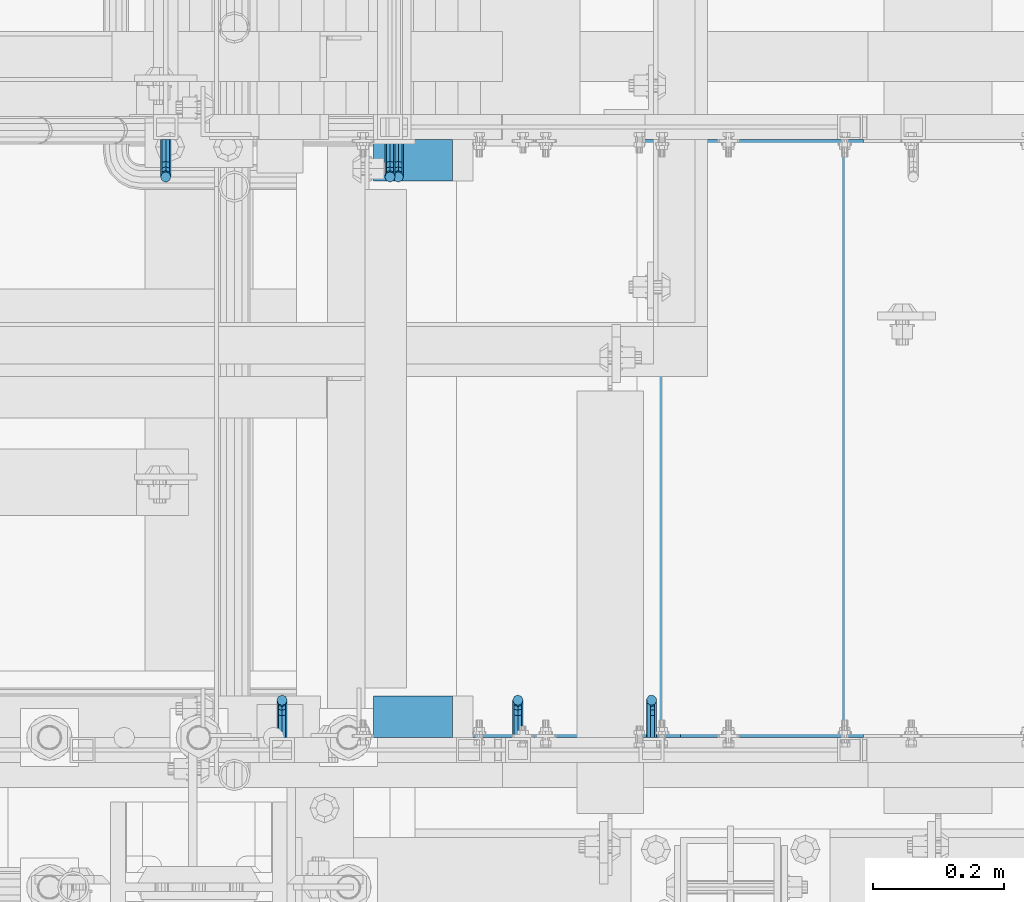
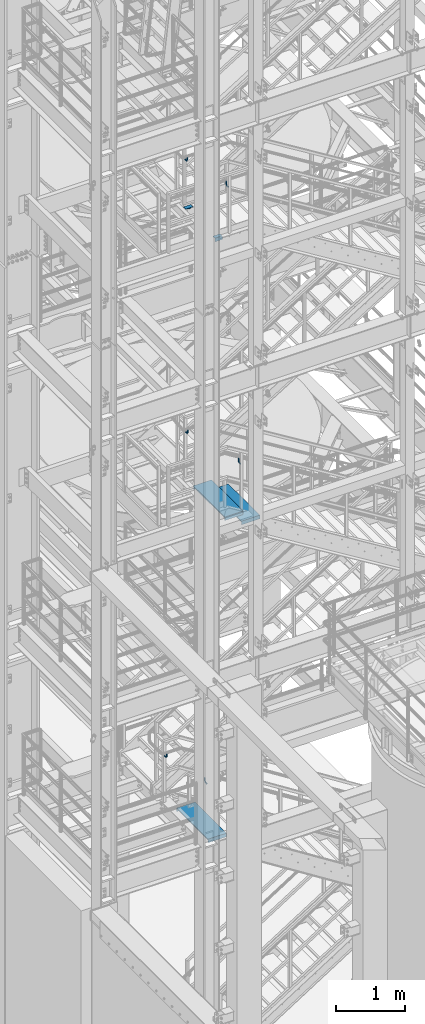
# One storey, part 1135 of 1876: 11 beams, 9 elements without a shape of their own.
"""IFC2X3 building model written with IfcOpenShell, lengths in millimetres."""

import ifcopenshell
import ifcopenshell.guid

model = None  # the IFC model being written
_history = None  # IfcOwnerHistory: only IFC2X3 demands one
_inside = {}  # id of a spatial element -> (the spatial element, [elements in it])
_under = {}  # id of a project, library or spatial element -> (it, [spatial elements below it])
_declared = {}  # id of a project -> (the project, [libraries it declares])
_typed = {}  # id of a type object -> (the type object, [elements of that type])
_made_of = {}  # id of a material, layer set ... -> (it, [elements and type objects made of it])


def new_model(schema):
    """Start an empty IFC model of exactly this schema.

    Asked for "IFC4X3", IfcOpenShell would pick the latest addendum, in which some entities
    have other attributes; the version numbers below select the first issue.
    IFC2X3 requires an IfcOwnerHistory on every rooted entity: one is made here for all.
    """
    global model, _history
    if schema == "IFC4X3":
        model = ifcopenshell.file(schema_version=(4, 3, 0, 0))
    else:
        model = ifcopenshell.file(schema=schema)
    _inside.clear()
    _under.clear()
    _declared.clear()
    _typed.clear()
    _made_of.clear()
    _history = None
    if model.schema == "IFC2X3":
        org = make("IfcOrganization", Name="unknown")
        user = make(
            "IfcPersonAndOrganization",
            ThePerson=make("IfcPerson", FamilyName="unknown"),
            TheOrganization=org,
        )
        app = make(
            "IfcApplication",
            ApplicationDeveloper=org,
            Version="unknown",
            ApplicationFullName="unknown",
            ApplicationIdentifier="unknown",
        )
        _history = make(
            "IfcOwnerHistory",
            OwningUser=user,
            OwningApplication=app,
            ChangeAction="ADDED",
            CreationDate=0,
        )
    return model


def make(cls, **values):
    """One entity of the class cls with the attributes given. An attribute that is None is left unset."""
    return model.create_entity(
        cls, **{name: value for name, value in values.items() if value is not None}
    )


def rooted(cls, **values):
    """An entity with a GlobalId (a new one), such as an element, a storey or a relation."""
    return make(cls, GlobalId=ifcopenshell.guid.new(), OwnerHistory=_history, **values)


def si_unit(unit_type, name, prefix=None):
    """IfcSIUnit, for example si_unit("LENGTHUNIT", "METRE", prefix="MILLI")."""
    return make("IfcSIUnit", UnitType=unit_type, Prefix=prefix, Name=name)


def assignment(units):
    """IfcUnitAssignment: the units of a project."""
    return None if units is None else make("IfcUnitAssignment", Units=units)


def point(xyz):
    """IfcCartesianPoint."""
    return None if xyz is None else make("IfcCartesianPoint", Coordinates=xyz)


def direction(xyz):
    """IfcDirection."""
    return None if xyz is None else make("IfcDirection", DirectionRatios=xyz)


def frame(location, z_axis=None, x_axis=None):
    """IfcAxis2Placement3D, a coordinate frame: its origin and axes. An axis left out is left unset."""
    return make(
        "IfcAxis2Placement3D",
        Location=point(location),
        Axis=direction(z_axis),
        RefDirection=direction(x_axis),
    )


def origin_with_axes():
    """The frame at (0, 0, 0) with the z axis (0, 0, 1) and the x axis (1, 0, 0) written out."""
    return frame((0.0, 0.0, 0.0), z_axis=(0.0, 0.0, 1.0), x_axis=(1.0, 0.0, 0.0))


def place(relative_to, where):
    """IfcLocalPlacement: puts the frame where relative to a parent placement (None: the world)."""
    return make(
        "IfcLocalPlacement", PlacementRelTo=relative_to, RelativePlacement=where
    )


def context(
    kind, dimensions, precision=None, world=None, true_north=None, identifier=None
):
    """IfcGeometricRepresentationContext, for example the 3D "Model" context."""
    return make(
        "IfcGeometricRepresentationContext",
        ContextIdentifier=identifier,
        ContextType=kind,
        CoordinateSpaceDimension=dimensions,
        Precision=precision,
        WorldCoordinateSystem=world,
        TrueNorth=true_north,
    )


def subcontext(parent, identifier, kind, view, scale=None):
    """IfcGeometricRepresentationSubContext, for example "Body" below "Model"."""
    return make(
        "IfcGeometricRepresentationSubContext",
        ContextIdentifier=identifier,
        ContextType=kind,
        ParentContext=parent,
        TargetScale=scale,
        TargetView=view,
    )


def project(units=None, contexts=None):
    """IfcProject with its units and contexts."""
    return rooted(
        "IfcProject",
        Name="project",
        RepresentationContexts=contexts,
        UnitsInContext=assignment(units),
    )


def spatial(cls, under=None, at=None, **own):
    """A site, building, storey or space (cls), placed at a placement, below another one or the project."""
    s = rooted(cls, ObjectPlacement=at, **own)
    if under is not None:
        _under.setdefault(under.id(), (under, []))[1].append(s)
    return s


def faces_of(points, faces, orient=None, outer=None):
    """IfcFace entities. A face is a list of loops; a loop is a list of indices into points, from 0.

    orient and outer hold one flag for each loop. By default every Orientation is true, the
    first loop of a face is its IfcFaceOuterBound and the others are IfcFaceBound.
    """
    made = []
    for i, loops in enumerate(faces):
        bounds = []
        for j, loop in enumerate(loops):
            is_outer = j == 0 if outer is None else outer[i][j]
            bounds.append(
                make(
                    "IfcFaceOuterBound" if is_outer else "IfcFaceBound",
                    Bound=make("IfcPolyLoop", Polygon=[points[k] for k in loop]),
                    Orientation=True if orient is None else orient[i][j],
                )
            )
        made.append(make("IfcFace", Bounds=bounds))
    return made


def faceted_brep(points, faces, orient=None, outer=None, voids=None):
    """IfcFacetedBrep: a solid bounded by flat faces; with voids (closed shells), ...WithVoids."""
    shared = [point(p) for p in points]
    hull = make("IfcClosedShell", CfsFaces=faces_of(shared, faces, orient, outer))
    if voids is None:
        return make("IfcFacetedBrep", Outer=hull)
    return make(
        "IfcFacetedBrepWithVoids",
        Outer=hull,
        Voids=[
            make(cls, CfsFaces=faces_of(shared, fs, o, b)) for cls, fs, o, b in voids
        ],
    )


def shape(context_of_items, identifier, shape_type, items):
    """IfcShapeRepresentation: the items that make up one representation, for example the "Body"."""
    return make(
        "IfcShapeRepresentation",
        ContextOfItems=context_of_items,
        RepresentationIdentifier=identifier,
        RepresentationType=shape_type,
        Items=items,
    )


def material(Name=None, Category=None):
    """IfcMaterial."""
    return make("IfcMaterial", Name=Name, Category=Category)


def made_of(thing, what):
    """Note that an element or type object is made of a material, layer set ...; save() writes the relation."""
    if what is not None:
        _made_of.setdefault(what.id(), (what, []))[1].append(thing)
    return thing


def type_object(cls, material=None, **own):
    """A type object (cls), such as IfcWallType, which elements share."""
    return made_of(rooted(cls, **own), material)


def element(
    cls,
    number,
    at=None,
    inside=None,
    cuts=None,
    type_object=None,
    material=None,
    context=None,
    identifier="Body",
    shape_type=None,
    held_by="IfcProductDefinitionShape",
    body=None,
    shapes=None,
    **own,
):
    """One element of the class cls, such as IfcWall. Its Tag is "e" and its number.

    at: its placement. inside: the storey or other place that contains it. cuts: it is an
    opening in that element (IfcRelVoidsElement). A single representation is given by context,
    identifier, shape_type and body (its items); several are given by shapes. held_by: the class
    of the entity that holds the representations. save() writes the other relations.
    """
    e = rooted(cls, Tag="e%d" % number, ObjectPlacement=at, **own)
    if body is not None:
        shapes = [shape(context, identifier, shape_type, body)]
    if shapes is not None:
        e.Representation = make(held_by, Representations=shapes)
    if inside is not None:
        _inside.setdefault(inside.id(), (inside, []))[1].append(e)
    if cuts is not None:
        rooted(
            "IfcRelVoidsElement", RelatingBuildingElement=cuts, RelatedOpeningElement=e
        )
    if type_object is not None:
        _typed.setdefault(type_object.id(), (type_object, []))[1].append(e)
    return made_of(e, material)


def aggregate(whole, parts):
    """IfcRelAggregates: a whole, such as a stair, and the parts it consists of."""
    return rooted("IfcRelAggregates", RelatingObject=whole, RelatedObjects=parts)


def save(model, path):
    """Write the relations noted so far, then the file.

    IfcRelAggregates (storeys below a building ...), IfcRelContainedInSpatialStructure (elements
    in a storey), IfcRelDefinesByType, IfcRelAssociatesMaterial and IfcRelDeclares: one each for
    every whole, place, type object, material and project.
    """
    for whole, parts in _under.values():
        aggregate(whole, parts)
    for where, things in _inside.values():
        rooted(
            "IfcRelContainedInSpatialStructure",
            RelatedElements=things,
            RelatingStructure=where,
        )
    for kind, things in _typed.values():
        rooted("IfcRelDefinesByType", RelatedObjects=things, RelatingType=kind)
    for what, things in _made_of.values():
        rooted("IfcRelAssociatesMaterial", RelatedObjects=things, RelatingMaterial=what)
    for by, libraries in _declared.values():
        rooted("IfcRelDeclares", RelatingContext=by, RelatedDefinitions=libraries)
    model.write(path)


model = new_model("IFC2X3")

# Units and contexts
model_context = context("Model", 3, precision=1e-05, world=origin_with_axes())
body_context = subcontext(model_context, "Body", "Model", "MODEL_VIEW")
ifc_project = project(units=[si_unit("LENGTHUNIT", "METRE", prefix="MILLI"), si_unit("AREAUNIT", "SQUARE_METRE"), si_unit("VOLUMEUNIT", "CUBIC_METRE"), si_unit("MASSUNIT", "GRAM", prefix="KILO"), si_unit("TIMEUNIT", "SECOND"), si_unit("PLANEANGLEUNIT", "RADIAN"), si_unit("SOLIDANGLEUNIT", "STERADIAN"), si_unit("THERMODYNAMICTEMPERATUREUNIT", "DEGREE_CELSIUS"), si_unit("LUMINOUSINTENSITYUNIT", "LUMEN")], contexts=[model_context])

# Site, building, storey
site_placement = place(None, origin_with_axes())
site = spatial("IfcSite", under=ifc_project, at=site_placement, CompositionType="ELEMENT")
building_placement = place(site_placement, origin_with_axes())
building = spatial("IfcBuilding", under=site, at=building_placement, Name="Undefined", CompositionType="ELEMENT")
storey_placement = place(building_placement, origin_with_axes())
storey = spatial("IfcBuildingStorey", under=building, at=storey_placement, Name="Undefined", CompositionType="ELEMENT", Elevation=0.0)

# Assembly, beams
assembly_1_placement = place(storey_placement, origin_with_axes())
assembly_1 = element("IfcElementAssembly", 1, at=assembly_1_placement, inside=storey, Name="STRINGER", AssemblyPlace="NOTDEFINED", PredefinedType="RIGID_FRAME")
ifc_material = material(Name="STEEL/A36")
beam_type_1 = type_object("IfcBeamType", Name="L2-1/2X2-1/2X1/4", PredefinedType="NOTDEFINED")
beam_1_placement = place(assembly_1_placement, frame((1993.89992675781, -6000.74999885443, 15531.2768518519), z_axis=(0.0, -1.0, 0.0), x_axis=(1.0, 0.0, 0.0)))
beam_1 = element("IfcBeam", 2, at=beam_1_placement, type_object=beam_type_1, material=ifc_material, Name="ANGLE", ObjectType="L2-1/2X2-1/2X1/4", context=body_context, shape_type="Brep", body=[
    faceted_brep([(0.0, 18.9900739633831, -25.3999999999996), (0.0, 18.9900743443777, -31.75), (76.2000738000577, 18.9900747300744, -31.75), (76.2000738000577, 18.990074349078, -25.3999999999996), (76.200071516754, -31.7499998086369, -25.3999999999996), (76.200071516754, -31.75, -31.75), (0.0, 25.3999999999996, 31.75), (0.0, 25.3999999999996, -25.3999999999996), (120.650073242187, 25.3999999999996, -25.3999999999996), (120.650073242187, 25.3999999999996, 31.75), (0.0, 31.75, 31.75), (120.650073242187, 31.75, 31.75), (0.0, 31.75, -31.75), (120.650073242187, 31.75, -31.75), (120.650073242187, -31.75, -25.3999999999996), (120.650073242187, -31.75, -31.75)], [[[0, 1, 2, 3]], [[4, 3, 2, 5]], [[6, 7, 8, 9]], [[10, 6, 9, 11]], [[12, 10, 11, 13]], [[9, 8, 14, 15, 13, 11]], [[15, 14, 4, 5]], [[1, 12, 13, 15, 5, 2]], [[7, 6, 10, 12, 1, 0]], [[14, 8, 7, 0, 3, 4]]]),
])
beam_2_placement = place(assembly_1_placement, frame((2114.55, -6851.65000114557, 15531.2768518519), z_axis=(0.0, 1.0, 0.0), x_axis=(-1.0, 0.0, 0.0)))
beam_2 = element("IfcBeam", 3, at=beam_2_placement, type_object=beam_type_1, material=ifc_material, Name="ANGLE", ObjectType="L2-1/2X2-1/2X1/4", context=body_context, shape_type="Brep", body=[
    faceted_brep([(0.0, 31.75, -31.75), (0.0, 31.75, 31.75), (120.650073242187, 31.75, 31.75), (120.650073242187, 31.75, -31.75), (0.0, 25.3999999999996, 31.75), (120.650073242187, 25.3999999999996, 31.75), (0.0, 25.3999999999996, -25.3999999999996), (120.650073242187, 25.3999999999996, -25.3999999999996), (0.0, -31.75, -25.3999999999996), (120.650073242187, -31.75, -25.3999999999996), (0.0, -31.75, -31.75), (120.650073242187, -31.75, -31.75)], [[[0, 1, 2, 3]], [[1, 4, 5, 2]], [[4, 6, 7, 5]], [[6, 8, 9, 7]], [[8, 10, 11, 9]], [[10, 0, 3, 11]], [[5, 7, 9, 11, 3, 2]], [[10, 8, 6, 4, 1, 0]]]),
])
aggregate(assembly_1, [beam_1, beam_2])

# Assembly, beam
assembly_2_placement = place(storey_placement, origin_with_axes())
assembly_2 = element("IfcElementAssembly", 4, at=assembly_2_placement, inside=storey, Name="RAIL", AssemblyPlace="NOTDEFINED", PredefinedType="RIGID_FRAME")
beam_type_2 = type_object("IfcBeamType", PredefinedType="NOTDEFINED")
beam_3_placement = place(assembly_2_placement, frame((1676.39999604434, -5969.00000106773, 5956.3), z_axis=(-1.0, 0.0, 0.0), x_axis=(0.0, -1.0, 0.0)))
beam_3 = element("IfcBeam", 5, at=beam_3_placement, type_object=beam_type_2, material=ifc_material, Name="BRACKET", context=body_context, shape_type="Brep", body=[
    faceted_brep([(0.0, -7.9375, 0.0), (0.0, -5.61266007566822, -5.61266007566883), (23.8125, -5.61266007566883, -5.61266007566792), (23.8125, -7.9375, 0.0), (0.0, 0.0, -7.9375), (23.8125, 0.0, -7.9375), (0.0, 5.61266007566822, -5.61266007566883), (23.8125, 5.61266007566883, -5.61266007566792), (0.0, 7.9375, 0.0), (23.8125, 7.9375, 0.0), (0.0, 5.61266007566822, 5.61266007566883), (23.8125, 5.61266007566883, 5.61266007566792), (0.0, 0.0, 7.9375), (23.8125, 0.0, 7.9375), (0.0, -5.61266007566822, 5.61266007566883), (23.8125, -5.61266007566883, 5.61266007566792), (39.6077592547981, -4.79562758825341, 0.0), (38.7180815328556, -2.64775556579843, 5.61266007566792), (36.5702095103998, 2.53766620105671, 7.9375), (34.4223374879448, 7.72308796790821, 5.61266007566792), (33.5326597660023, 9.87095999036319, 0.0), (34.4223374879448, 7.72308796790821, -5.61266007566792), (36.5702095103998, 2.53766620105671, -7.9375), (38.7180815328556, -2.64775556579843, -5.61266007566792), (51.3544233967659, 5.79557812911298, -5.61266007566792), (52.9983334724348, 4.15166805344415, 0.0), (47.3856733967659, 9.76432812911298, -7.9375), (43.4169233967659, 13.733078129113, -5.61266007566792), (41.773013321098, 15.3769882047818, 0.0), (43.4169233967659, 13.733078129113, 5.61266007566792), (47.3856733967659, 9.76432812911298, 7.9375), (51.3544233967659, 5.79557812911298, 5.61266007566792), (59.7977570916764, 18.4319199930251, -5.61266007566792), (61.9456291141314, 17.5422422710835, 0.0), (54.6123353248231, 20.5797920154801, -7.9375), (49.4269135579698, 22.727664037935, -5.61266007566792), (47.2790415355148, 23.6173417598766, 0.0), (49.4269135579698, 22.727664037935, 5.61266007566792), (54.6123353248231, 20.5797920154801, 7.9375), (59.7977570916764, 18.4319199930251, 5.61266007566792), (62.7626616015468, 33.3375015258789, -5.61266007566792), (65.0875015258789, 33.3375015258789, 0.0), (57.1500015258789, 33.3375015258789, -7.9375), (51.5373414502101, 33.3375015258789, -5.61266007566792), (49.2125015258789, 33.3375015258789, 0.0), (51.5373414502101, 33.3375015258789, 5.61266007566792), (57.1500015258789, 33.3375015258789, 7.9375), (62.7626616015468, 33.3375015258789, 5.61266007566792), (62.7626616015468, 69.8499984741211, -5.61266007566792), (65.0875015258789, 69.8499984741211, 0.0), (57.1500015258789, 69.8499984741211, -7.9375), (51.537341450211, 69.8499984741211, -5.61266007566792), (49.2125015258789, 69.8499984741211, 0.0), (51.537341450211, 69.8499984741211, 5.61266007566792), (57.1500015258789, 69.8499984741211, 7.9375), (62.7626616015468, 69.8499984741211, 5.61266007566792)], [[[0, 1, 2, 3]], [[1, 4, 5, 2]], [[4, 6, 7, 5]], [[6, 8, 9, 7]], [[8, 10, 11, 9]], [[10, 12, 13, 11]], [[12, 14, 15, 13]], [[14, 0, 3, 15]], [[14, 12, 10, 8, 6, 4, 1, 0]], [[15, 3, 16, 17]], [[13, 15, 17, 18]], [[11, 13, 18, 19]], [[9, 11, 19, 20]], [[7, 9, 20, 21]], [[5, 7, 21, 22]], [[2, 5, 22, 23]], [[3, 2, 23, 16]], [[23, 24, 25, 16]], [[22, 26, 24, 23]], [[21, 27, 26, 22]], [[20, 28, 27, 21]], [[19, 29, 28, 20]], [[18, 30, 29, 19]], [[17, 31, 30, 18]], [[16, 25, 31, 17]], [[24, 32, 33, 25]], [[26, 34, 32, 24]], [[27, 35, 34, 26]], [[28, 36, 35, 27]], [[29, 37, 36, 28]], [[30, 38, 37, 29]], [[31, 39, 38, 30]], [[25, 33, 39, 31]], [[32, 40, 41, 33]], [[34, 42, 40, 32]], [[35, 43, 42, 34]], [[36, 44, 43, 35]], [[37, 45, 44, 36]], [[38, 46, 45, 37]], [[39, 47, 46, 38]], [[33, 41, 47, 39]], [[41, 40, 48, 49]], [[40, 42, 50, 48]], [[42, 43, 51, 50]], [[43, 44, 52, 51]], [[44, 45, 53, 52]], [[45, 46, 54, 53]], [[46, 47, 55, 54]], [[47, 41, 49, 55]], [[50, 51, 52, 53, 54, 55, 49, 48]]]),
])
aggregate(assembly_2, [beam_3])

assembly_3_placement = place(storey_placement, origin_with_axes())
assembly_3 = element("IfcElementAssembly", 6, at=assembly_3_placement, inside=storey, Name="RAIL", AssemblyPlace="NOTDEFINED", PredefinedType="RIGID_FRAME")
beam_4_placement = place(assembly_3_placement, frame((2419.3500007981, -6883.39999885446, 11421.9952072148), z_axis=(-0.851746923791363, 0.0, 0.523953411871657), x_axis=(0.0, 1.0, 0.0)))
beam_4 = element("IfcBeam", 7, at=beam_4_placement, type_object=beam_type_2, material=ifc_material, Name="BRACKET", context=body_context, shape_type="Brep", body=[
    faceted_brep([(0.0, -5.61266007566822, 5.61266007566883), (0.0, 0.0, 7.9375), (0.0, 5.61266007566822, 5.61266007566883), (0.0, 7.9375, 0.0), (0.0, 5.61266007566822, -5.61266007566883), (0.0, 0.0, -7.9375), (0.0, -5.61266007566822, -5.61266007566883), (0.0, -7.9375, 0.0), (23.8125, 7.9375, 0.0), (23.8125, 5.61266007566883, -5.61266007566792), (23.8125, 0.0, -7.9375), (23.8125, -5.61266007566883, -5.61266007566792), (23.8125, -7.9375, 0.0), (23.8125, -5.61266007566883, 5.61266007566792), (23.8125, 0.0, 7.9375), (23.8125, 5.61266007566883, 5.61266007566792), (37.2742680237907, 3.33192699189385, 7.01565649095653), (39.15743316105, 5.33771543479088, 1.59926141794483), (39.5250377726497, 2.95059483544173, -3.97508660603592), (38.1617440627024, -2.43109193407145, -6.44201010992776), (35.8661509970007, -7.65482575261558, -4.3564187624853), (33.9829858597423, -9.66061419551443, 1.05997631052549), (33.6153812481443, -7.27349359616528, 6.63432433450714), (34.9786749580899, -1.89180682665028, 9.10124783839899), (44.4449010004428, -7.27921686651098, 12.4153212945938), (48.6866038971966, -3.16305132232992, 11.0110522507902), (41.9258626896017, -12.0031473096369, 9.54377798901703), (42.605107443027, -14.5676282658369, 4.07853345752562), (46.0847428963316, -13.4704215714119, -0.778946175020906), (50.3264457930854, -9.35425602723262, -2.18321521882456), (52.8454841039247, -4.63032558410305, 0.688328086752222), (52.1662393505012, -2.0658446279067, 6.15357261824545), (56.3120829365644, -12.8834732957839, 16.9905845690854), (60.8584457511233, -13.1460552819772, 12.9695810055836), (50.7700310236578, -15.3420457780048, 17.3751827270333), (47.4787488596085, -19.0815743126295, 13.8980830945646), (48.3662248985192, -21.9114938009589, 8.59612347865811), (52.9125877130791, -22.1740757871521, 4.57511991515719), (58.4546396259857, -19.715503304933, 4.19052175720924), (61.7459217900359, -15.9759747703083, 7.66762138967886), (63.9107427334729, -26.2160548977063, 21.0096110902649), (64.8713398759373, -29.3590804831365, 15.9002591648249), (58.9897950832947, -24.3494927988595, 24.0439238549806), (52.991121319149, -24.8528009490874, 23.2257381938842), (49.4286631758196, -27.4311482600406, 19.0343361707063), (50.389260318284, -30.5741738454726, 13.9249842452672), (55.3102079684622, -32.4407359443194, 10.8906714805506), (61.3088817326088, -31.9374277940915, 11.7088571416479), (64.8713398759373, -56.6704316393188, 32.700878247072), (61.3088817326088, -56.6704314004855, 26.9234018184987), (55.3102079684622, -56.670431353863, 25.7956053568267), (50.389260318284, -56.6704315267634, 29.9781367337081), (49.4286631758196, -56.6704318179036, 37.0209257936175), (52.991121319149, -56.6704320567369, 42.7984022221907), (58.9897950832947, -56.6704321033558, 43.9261986838618), (63.9107427334739, -56.6704319304572, 39.7436673069795)], [[[0, 1, 2, 3, 4, 5, 6, 7]], [[4, 3, 8, 9]], [[5, 4, 9, 10]], [[6, 5, 10, 11]], [[7, 6, 11, 12]], [[0, 7, 12, 13]], [[1, 0, 13, 14]], [[2, 1, 14, 15]], [[3, 2, 15, 8]], [[8, 15, 16, 17]], [[9, 8, 17, 18]], [[10, 9, 18, 19]], [[11, 10, 19, 20]], [[12, 11, 20, 21]], [[13, 12, 21, 22]], [[14, 13, 22, 23]], [[15, 14, 23, 16]], [[23, 24, 25, 16]], [[22, 26, 24, 23]], [[21, 27, 26, 22]], [[20, 28, 27, 21]], [[19, 29, 28, 20]], [[18, 30, 29, 19]], [[17, 31, 30, 18]], [[16, 25, 31, 17]], [[25, 32, 33, 31]], [[24, 34, 32, 25]], [[26, 35, 34, 24]], [[27, 36, 35, 26]], [[28, 37, 36, 27]], [[29, 38, 37, 28]], [[30, 39, 38, 29]], [[31, 33, 39, 30]], [[33, 40, 41, 39]], [[32, 42, 40, 33]], [[34, 43, 42, 32]], [[35, 44, 43, 34]], [[36, 45, 44, 35]], [[37, 46, 45, 36]], [[38, 47, 46, 37]], [[39, 41, 47, 38]], [[47, 41, 48, 49]], [[46, 47, 49, 50]], [[45, 46, 50, 51]], [[44, 45, 51, 52]], [[43, 44, 52, 53]], [[42, 43, 53, 54]], [[40, 42, 54, 55]], [[41, 40, 55, 48]], [[54, 53, 52, 51, 50, 49, 48, 55]]]),
])
aggregate(assembly_3, [beam_4])

assembly_4_placement = place(storey_placement, origin_with_axes())
assembly_4 = element("IfcElementAssembly", 8, at=assembly_4_placement, inside=storey, Name="RAIL", AssemblyPlace="NOTDEFINED", PredefinedType="RIGID_FRAME")
beam_5_placement = place(assembly_4_placement, frame((2214.88000091923, -6883.39999885446, 16394.8768518518), z_axis=(-1.0, 0.0, 0.0), x_axis=(0.0, 1.0, 0.0)))
beam_5 = element("IfcBeam", 9, at=beam_5_placement, type_object=beam_type_2, material=ifc_material, Name="BRACKET", context=body_context, shape_type="Brep", body=[
    faceted_brep([(0.0, -7.9375, 0.0), (0.0, -5.61266007566822, -5.61266007566883), (23.8125, -5.61266007566883, -5.61266007566792), (23.8125, -7.9375, 0.0), (0.0, 0.0, -7.9375), (23.8125, 0.0, -7.9375), (0.0, 5.61266007566822, -5.61266007566883), (23.8125, 5.61266007566883, -5.61266007566792), (0.0, 7.9375, 0.0), (23.8125, 7.9375, 0.0), (0.0, 5.61266007566822, 5.61266007566883), (23.8125, 5.61266007566883, 5.61266007566792), (0.0, 0.0, 7.9375), (23.8125, 0.0, 7.9375), (0.0, -5.61266007566822, 5.61266007566883), (23.8125, -5.61266007566883, 5.61266007566792), (39.6077592547972, 4.79562758825296, 0.0), (38.7180815328547, 2.64775556579752, -5.61266007566792), (36.5702095103989, -2.53766620105534, -7.9375), (34.4223374879439, -7.72308796790867, -5.61266007566792), (33.5326597660014, -9.87095999036364, 0.0), (34.4223374879439, -7.72308796790867, 5.61266007566792), (36.5702095103989, -2.53766620105534, 7.9375), (38.7180815328547, 2.64775556579752, 5.61266007566792), (51.354423396765, -5.79557812911253, 5.61266007566792), (52.9983334724338, -4.15166805344461, 0.0), (47.385673396765, -9.76432812911298, 7.9375), (43.4169233967659, -13.733078129113, 5.61266007566792), (41.7730133210971, -15.3769882047809, 0.0), (43.4169233967659, -13.733078129113, -5.61266007566792), (47.385673396765, -9.76432812911298, -7.9375), (51.354423396765, -5.79557812911253, -5.61266007566792), (59.7977570916764, -18.4319199930233, 5.61266007566792), (61.9456291141314, -17.5422422710808, 0.0), (54.6123353248231, -20.5797920154787, 7.9375), (49.4269135579698, -22.7276640379341, 5.61266007566792), (47.2790415355148, -23.6173417598766, 0.0), (49.4269135579698, -22.7276640379341, -5.61266007566792), (54.6123353248231, -20.5797920154787, -7.9375), (59.7977570916764, -18.4319199930233, -5.61266007566792), (62.7626616015468, -33.3375015258789, 5.61266007566792), (65.0875015258789, -33.3375015258789, 0.0), (57.1500015258789, -33.3375015258789, 7.9375), (51.5373414502101, -33.3375015258789, 5.61266007566792), (49.2125015258789, -33.3375015258789, 0.0), (51.5373414502101, -33.3375015258789, -5.61266007566792), (57.1500015258789, -33.3375015258789, -7.9375), (62.7626616015468, -33.3375015258789, -5.61266007566792), (51.537341450211, -69.8499984741211, -5.61266007566792), (49.2125015258789, -69.8499984741211, 0.0), (57.1500015258789, -69.8499984741211, -7.9375), (62.7626616015468, -69.8499984741211, -5.61266007566792), (65.0875015258789, -69.8499984741211, 0.0), (62.7626616015468, -69.8499984741211, 5.61266007566792), (57.1500015258789, -69.8499984741211, 7.9375), (51.537341450211, -69.8499984741211, 5.61266007566792)], [[[0, 1, 2, 3]], [[1, 4, 5, 2]], [[4, 6, 7, 5]], [[6, 8, 9, 7]], [[8, 10, 11, 9]], [[10, 12, 13, 11]], [[12, 14, 15, 13]], [[14, 0, 3, 15]], [[14, 12, 10, 8, 6, 4, 1, 0]], [[7, 9, 16, 17]], [[5, 7, 17, 18]], [[2, 5, 18, 19]], [[3, 2, 19, 20]], [[15, 3, 20, 21]], [[13, 15, 21, 22]], [[11, 13, 22, 23]], [[9, 11, 23, 16]], [[23, 24, 25, 16]], [[22, 26, 24, 23]], [[21, 27, 26, 22]], [[20, 28, 27, 21]], [[19, 29, 28, 20]], [[18, 30, 29, 19]], [[17, 31, 30, 18]], [[16, 25, 31, 17]], [[24, 32, 33, 25]], [[26, 34, 32, 24]], [[27, 35, 34, 26]], [[28, 36, 35, 27]], [[29, 37, 36, 28]], [[30, 38, 37, 29]], [[31, 39, 38, 30]], [[25, 33, 39, 31]], [[32, 40, 41, 33]], [[34, 42, 40, 32]], [[35, 43, 42, 34]], [[36, 44, 43, 35]], [[37, 45, 44, 36]], [[38, 46, 45, 37]], [[39, 47, 46, 38]], [[33, 41, 47, 39]], [[44, 45, 48, 49]], [[45, 46, 50, 48]], [[46, 47, 51, 50]], [[47, 41, 52, 51]], [[41, 40, 53, 52]], [[40, 42, 54, 53]], [[42, 43, 55, 54]], [[43, 44, 49, 55]], [[50, 51, 52, 53, 54, 55, 49, 48]]]),
])
aggregate(assembly_4, [beam_5])

assembly_5_placement = place(storey_placement, origin_with_axes())
assembly_5 = element("IfcElementAssembly", 10, at=assembly_5_placement, inside=storey, Name="RAIL", AssemblyPlace="NOTDEFINED", PredefinedType="RIGID_FRAME")
beam_6_placement = place(assembly_5_placement, frame((2019.30000114869, -5969.00000114554, 16394.8768518518), z_axis=(-1.0, 0.0, 0.0), x_axis=(0.0, -1.0, 0.0)))
beam_6 = element("IfcBeam", 11, at=beam_6_placement, type_object=beam_type_2, material=ifc_material, Name="BRACKET", context=body_context, shape_type="Brep", body=[
    faceted_brep([(0.0, -7.9375, 0.0), (0.0, -5.61266007566822, -5.61266007566883), (23.8125, -5.61266007566883, -5.61266007566792), (23.8125, -7.9375, 0.0), (0.0, 0.0, -7.9375), (23.8125, 0.0, -7.9375), (0.0, 5.61266007566822, -5.61266007566883), (23.8125, 5.61266007566883, -5.61266007566792), (0.0, 7.9375, 0.0), (23.8125, 7.9375, 0.0), (0.0, 5.61266007566822, 5.61266007566883), (23.8125, 5.61266007566883, 5.61266007566792), (0.0, 0.0, 7.9375), (23.8125, 0.0, 7.9375), (0.0, -5.61266007566822, 5.61266007566883), (23.8125, -5.61266007566883, 5.61266007566792), (39.6077592547981, -4.79562758825341, 0.0), (38.7180815328556, -2.64775556579843, 5.61266007566792), (36.5702095103998, 2.53766620105671, 7.9375), (34.4223374879448, 7.72308796790821, 5.61266007566792), (33.5326597660023, 9.87095999036319, 0.0), (34.4223374879448, 7.72308796790821, -5.61266007566792), (36.5702095103998, 2.53766620105671, -7.9375), (38.7180815328556, -2.64775556579843, -5.61266007566792), (51.3544233967659, 5.79557812911298, -5.61266007566792), (52.9983334724348, 4.15166805344415, 0.0), (47.3856733967659, 9.76432812911298, -7.9375), (43.4169233967659, 13.733078129113, -5.61266007566792), (41.773013321098, 15.3769882047818, 0.0), (43.4169233967659, 13.733078129113, 5.61266007566792), (47.3856733967659, 9.76432812911298, 7.9375), (51.3544233967659, 5.79557812911298, 5.61266007566792), (59.7977570916764, 18.4319199930251, -5.61266007566792), (61.9456291141314, 17.5422422710835, 0.0), (54.6123353248231, 20.5797920154801, -7.9375), (49.4269135579698, 22.727664037935, -5.61266007566792), (47.2790415355148, 23.6173417598766, 0.0), (49.4269135579698, 22.727664037935, 5.61266007566792), (54.6123353248231, 20.5797920154801, 7.9375), (59.7977570916764, 18.4319199930251, 5.61266007566792), (62.7626616015468, 33.3375015258789, -5.61266007566792), (65.0875015258789, 33.3375015258789, 0.0), (57.1500015258789, 33.3375015258789, -7.9375), (51.5373414502101, 33.3375015258789, -5.61266007566792), (49.2125015258789, 33.3375015258789, 0.0), (51.5373414502101, 33.3375015258789, 5.61266007566792), (57.1500015258789, 33.3375015258789, 7.9375), (62.7626616015468, 33.3375015258789, 5.61266007566792), (62.7626616015468, 69.8499984741211, -5.61266007566792), (65.0875015258789, 69.8499984741211, 0.0), (57.1500015258789, 69.8499984741211, -7.9375), (51.537341450211, 69.8499984741211, -5.61266007566792), (49.2125015258789, 69.8499984741211, 0.0), (51.537341450211, 69.8499984741211, 5.61266007566792), (57.1500015258789, 69.8499984741211, 7.9375), (62.7626616015468, 69.8499984741211, 5.61266007566792)], [[[0, 1, 2, 3]], [[1, 4, 5, 2]], [[4, 6, 7, 5]], [[6, 8, 9, 7]], [[8, 10, 11, 9]], [[10, 12, 13, 11]], [[12, 14, 15, 13]], [[14, 0, 3, 15]], [[14, 12, 10, 8, 6, 4, 1, 0]], [[15, 3, 16, 17]], [[13, 15, 17, 18]], [[11, 13, 18, 19]], [[9, 11, 19, 20]], [[7, 9, 20, 21]], [[5, 7, 21, 22]], [[2, 5, 22, 23]], [[3, 2, 23, 16]], [[23, 24, 25, 16]], [[22, 26, 24, 23]], [[21, 27, 26, 22]], [[20, 28, 27, 21]], [[19, 29, 28, 20]], [[18, 30, 29, 19]], [[17, 31, 30, 18]], [[16, 25, 31, 17]], [[24, 32, 33, 25]], [[26, 34, 32, 24]], [[27, 35, 34, 26]], [[28, 36, 35, 27]], [[29, 37, 36, 28]], [[30, 38, 37, 29]], [[31, 39, 38, 30]], [[25, 33, 39, 31]], [[32, 40, 41, 33]], [[34, 42, 40, 32]], [[35, 43, 42, 34]], [[36, 44, 43, 35]], [[37, 45, 44, 36]], [[38, 46, 45, 37]], [[39, 47, 46, 38]], [[33, 41, 47, 39]], [[41, 40, 48, 49]], [[40, 42, 50, 48]], [[42, 43, 51, 50]], [[43, 44, 52, 51]], [[44, 45, 53, 52]], [[45, 46, 54, 53]], [[46, 47, 55, 54]], [[47, 41, 49, 55]], [[50, 51, 52, 53, 54, 55, 49, 48]]]),
])
aggregate(assembly_5, [beam_6])

assembly_6_placement = place(storey_placement, origin_with_axes())
assembly_6 = element("IfcElementAssembly", 12, at=assembly_6_placement, inside=storey, Name="RAIL", AssemblyPlace="NOTDEFINED", PredefinedType="RIGID_FRAME")
beam_7_placement = place(assembly_6_placement, frame((2032.00000177077, -5969.00000114554, 11566.525), z_axis=(-1.0, 0.0, 0.0), x_axis=(0.0, -1.0, 0.0)))
beam_7 = element("IfcBeam", 13, at=beam_7_placement, type_object=beam_type_2, material=ifc_material, Name="BRACKET", context=body_context, shape_type="Brep", body=[
    faceted_brep([(0.0, -7.9375, 0.0), (0.0, -5.61266007566822, -5.61266007566883), (23.8125, -5.61266007566883, -5.61266007566792), (23.8125, -7.9375, 0.0), (0.0, 0.0, -7.9375), (23.8125, 0.0, -7.9375), (0.0, 5.61266007566822, -5.61266007566883), (23.8125, 5.61266007566883, -5.61266007566792), (0.0, 7.9375, 0.0), (23.8125, 7.9375, 0.0), (0.0, 5.61266007566822, 5.61266007566883), (23.8125, 5.61266007566883, 5.61266007566792), (0.0, 0.0, 7.9375), (23.8125, 0.0, 7.9375), (0.0, -5.61266007566822, 5.61266007566883), (23.8125, -5.61266007566883, 5.61266007566792), (39.6077592547981, -4.79562758825341, 0.0), (38.7180815328556, -2.64775556579843, 5.61266007566792), (36.5702095103998, 2.53766620105671, 7.9375), (34.4223374879448, 7.72308796790821, 5.61266007566792), (33.5326597660023, 9.87095999036319, 0.0), (34.4223374879448, 7.72308796790821, -5.61266007566792), (36.5702095103998, 2.53766620105671, -7.9375), (38.7180815328556, -2.64775556579843, -5.61266007566792), (51.3544233967659, 5.79557812911298, -5.61266007566792), (52.9983334724348, 4.15166805344415, 0.0), (47.3856733967659, 9.76432812911298, -7.9375), (43.4169233967659, 13.733078129113, -5.61266007566792), (41.773013321098, 15.3769882047818, 0.0), (43.4169233967659, 13.733078129113, 5.61266007566792), (47.3856733967659, 9.76432812911298, 7.9375), (51.3544233967659, 5.79557812911298, 5.61266007566792), (59.7977570916764, 18.4319199930251, -5.61266007566792), (61.9456291141314, 17.5422422710835, 0.0), (54.6123353248231, 20.5797920154801, -7.9375), (49.4269135579698, 22.727664037935, -5.61266007566792), (47.2790415355148, 23.6173417598766, 0.0), (49.4269135579698, 22.727664037935, 5.61266007566792), (54.6123353248231, 20.5797920154801, 7.9375), (59.7977570916764, 18.4319199930251, 5.61266007566792), (62.7626616015468, 33.3375015258789, -5.61266007566792), (65.0875015258789, 33.3375015258789, 0.0), (57.1500015258789, 33.3375015258789, -7.9375), (51.5373414502101, 33.3375015258789, -5.61266007566792), (49.2125015258789, 33.3375015258789, 0.0), (51.5373414502101, 33.3375015258789, 5.61266007566792), (57.1500015258789, 33.3375015258789, 7.9375), (62.7626616015468, 33.3375015258789, 5.61266007566792), (62.7626616015468, 69.8499984741211, -5.61266007566792), (65.0875015258789, 69.8499984741211, 0.0), (57.1500015258789, 69.8499984741211, -7.9375), (51.537341450211, 69.8499984741211, -5.61266007566792), (49.2125015258789, 69.8499984741211, 0.0), (51.537341450211, 69.8499984741211, 5.61266007566792), (57.1500015258789, 69.8499984741211, 7.9375), (62.7626616015468, 69.8499984741211, 5.61266007566792)], [[[0, 1, 2, 3]], [[1, 4, 5, 2]], [[4, 6, 7, 5]], [[6, 8, 9, 7]], [[8, 10, 11, 9]], [[10, 12, 13, 11]], [[12, 14, 15, 13]], [[14, 0, 3, 15]], [[14, 12, 10, 8, 6, 4, 1, 0]], [[15, 3, 16, 17]], [[13, 15, 17, 18]], [[11, 13, 18, 19]], [[9, 11, 19, 20]], [[7, 9, 20, 21]], [[5, 7, 21, 22]], [[2, 5, 22, 23]], [[3, 2, 23, 16]], [[23, 24, 25, 16]], [[22, 26, 24, 23]], [[21, 27, 26, 22]], [[20, 28, 27, 21]], [[19, 29, 28, 20]], [[18, 30, 29, 19]], [[17, 31, 30, 18]], [[16, 25, 31, 17]], [[24, 32, 33, 25]], [[26, 34, 32, 24]], [[27, 35, 34, 26]], [[28, 36, 35, 27]], [[29, 37, 36, 28]], [[30, 38, 37, 29]], [[31, 39, 38, 30]], [[25, 33, 39, 31]], [[32, 40, 41, 33]], [[34, 42, 40, 32]], [[35, 43, 42, 34]], [[36, 44, 43, 35]], [[37, 45, 44, 36]], [[38, 46, 45, 37]], [[39, 47, 46, 38]], [[33, 41, 47, 39]], [[41, 40, 48, 49]], [[40, 42, 50, 48]], [[42, 43, 51, 50]], [[43, 44, 52, 51]], [[44, 45, 53, 52]], [[45, 46, 54, 53]], [[46, 47, 55, 54]], [[47, 41, 49, 55]], [[50, 51, 52, 53, 54, 55, 49, 48]]]),
])
aggregate(assembly_6, [beam_7])

assembly_7_placement = place(storey_placement, origin_with_axes())
assembly_7 = element("IfcElementAssembly", 14, at=assembly_7_placement, inside=storey, Name="RAIL", AssemblyPlace="NOTDEFINED", PredefinedType="RIGID_FRAME")
beam_8_placement = place(assembly_7_placement, frame((1854.20000610992, -6883.39999893226, 5956.29995166792), z_axis=(-1.0, 0.0, 0.0), x_axis=(0.0, 1.0, 0.0)))
beam_8 = element("IfcBeam", 15, at=beam_8_placement, type_object=beam_type_2, material=ifc_material, Name="BRACKET", context=body_context, shape_type="Brep", body=[
    faceted_brep([(0.0, -7.9375, 0.0), (0.0, -5.61266007566822, -5.61266007566883), (23.8125, -5.61266007566883, -5.61266007566792), (23.8125, -7.9375, 0.0), (0.0, 0.0, -7.9375), (23.8125, 0.0, -7.9375), (0.0, 5.61266007566822, -5.61266007566883), (23.8125, 5.61266007566883, -5.61266007566792), (0.0, 7.9375, 0.0), (23.8125, 7.9375, 0.0), (0.0, 5.61266007566822, 5.61266007566883), (23.8125, 5.61266007566883, 5.61266007566792), (0.0, 0.0, 7.9375), (23.8125, 0.0, 7.9375), (0.0, -5.61266007566822, 5.61266007566883), (23.8125, -5.61266007566883, 5.61266007566792), (39.6077592547972, 4.79562758825296, 0.0), (38.7180815328547, 2.64775556579752, -5.61266007566792), (36.5702095103989, -2.53766620105534, -7.9375), (34.4223374879439, -7.72308796790867, -5.61266007566792), (33.5326597660014, -9.87095999036364, 0.0), (34.4223374879439, -7.72308796790867, 5.61266007566792), (36.5702095103989, -2.53766620105534, 7.9375), (38.7180815328547, 2.64775556579752, 5.61266007566792), (51.354423396765, -5.79557812911253, 5.61266007566792), (52.9983334724338, -4.15166805344461, 0.0), (47.385673396765, -9.76432812911298, 7.9375), (43.4169233967659, -13.733078129113, 5.61266007566792), (41.7730133210971, -15.3769882047809, 0.0), (43.4169233967659, -13.733078129113, -5.61266007566792), (47.385673396765, -9.76432812911298, -7.9375), (51.354423396765, -5.79557812911253, -5.61266007566792), (59.7977570916764, -18.4319199930233, 5.61266007566792), (61.9456291141314, -17.5422422710808, 0.0), (54.6123353248231, -20.5797920154787, 7.9375), (49.4269135579698, -22.7276640379341, 5.61266007566792), (47.2790415355148, -23.6173417598766, 0.0), (49.4269135579698, -22.7276640379341, -5.61266007566792), (54.6123353248231, -20.5797920154787, -7.9375), (59.7977570916764, -18.4319199930233, -5.61266007566792), (62.7626616015468, -33.3375015258789, 5.61266007566792), (65.0875015258789, -33.3375015258789, 0.0), (57.1500015258789, -33.3375015258789, 7.9375), (51.5373414502101, -33.3375015258789, 5.61266007566792), (49.2125015258789, -33.3375015258789, 0.0), (51.5373414502101, -33.3375015258789, -5.61266007566792), (57.1500015258789, -33.3375015258789, -7.9375), (62.7626616015468, -33.3375015258789, -5.61266007566792), (51.537341450211, -69.8499984741211, -5.61266007566792), (49.2125015258789, -69.8499984741211, 0.0), (57.1500015258789, -69.8499984741211, -7.9375), (62.7626616015468, -69.8499984741211, -5.61266007566792), (65.0875015258789, -69.8499984741211, 0.0), (62.7626616015468, -69.8499984741211, 5.61266007566792), (57.1500015258789, -69.8499984741211, 7.9375), (51.537341450211, -69.8499984741211, 5.61266007566792)], [[[0, 1, 2, 3]], [[1, 4, 5, 2]], [[4, 6, 7, 5]], [[6, 8, 9, 7]], [[8, 10, 11, 9]], [[10, 12, 13, 11]], [[12, 14, 15, 13]], [[14, 0, 3, 15]], [[14, 12, 10, 8, 6, 4, 1, 0]], [[7, 9, 16, 17]], [[5, 7, 17, 18]], [[2, 5, 18, 19]], [[3, 2, 19, 20]], [[15, 3, 20, 21]], [[13, 15, 21, 22]], [[11, 13, 22, 23]], [[9, 11, 23, 16]], [[23, 24, 25, 16]], [[22, 26, 24, 23]], [[21, 27, 26, 22]], [[20, 28, 27, 21]], [[19, 29, 28, 20]], [[18, 30, 29, 19]], [[17, 31, 30, 18]], [[16, 25, 31, 17]], [[24, 32, 33, 25]], [[26, 34, 32, 24]], [[27, 35, 34, 26]], [[28, 36, 35, 27]], [[29, 37, 36, 28]], [[30, 38, 37, 29]], [[31, 39, 38, 30]], [[25, 33, 39, 31]], [[32, 40, 41, 33]], [[34, 42, 40, 32]], [[35, 43, 42, 34]], [[36, 44, 43, 35]], [[37, 45, 44, 36]], [[38, 46, 45, 37]], [[39, 47, 46, 38]], [[33, 41, 47, 39]], [[44, 45, 48, 49]], [[45, 46, 50, 48]], [[46, 47, 51, 50]], [[47, 41, 52, 51]], [[41, 40, 53, 52]], [[40, 42, 54, 53]], [[42, 43, 55, 54]], [[43, 44, 49, 55]], [[50, 51, 52, 53, 54, 55, 49, 48]]]),
])
aggregate(assembly_7, [beam_8])

# Assembly, beams
assembly_8_placement = place(storey_placement, origin_with_axes())
assembly_8 = element("IfcElementAssembly", 16, at=assembly_8_placement, inside=storey, Name="STRINGER", AssemblyPlace="NOTDEFINED", PredefinedType="RIGID_FRAME")
beam_type_3 = type_object("IfcBeamType", PredefinedType="NOTDEFINED")
beam_9_placement = place(assembly_8_placement, frame((2309.81250121991, -5973.76300114394, 10559.6266675622), z_axis=(1.0, 0.0, 0.0), x_axis=(0.0, -1.0, 0.0)))
beam_9 = element("IfcBeam", 17, at=beam_9_placement, type_object=beam_type_3, material=ifc_material, Name="TREAD", context=body_context, shape_type="Brep", body=[
    faceted_brep([(-7.45785655453801e-11, 53.9750000000167, -153.9875), (-7.45785655453801e-11, 53.9750000000167, 153.987506103515), (0.0, 9.52499999999964, 153.9875), (-7.45785655453801e-11, 9.52499999999964, -153.9875), (-4.76300000007541, 53.9750000000167, -153.9875), (-4.76300000007541, 53.9750000000167, 153.987506103515), (-4.76300000007541, -9.52499999998327, -153.9875), (-4.76300000007541, -9.52500000019427, 153.987536621094), (909.637000008669, -9.52500000248983, 153.987506103515), (909.637000008669, 53.9749999975102, 153.987506103515), (904.87400000867, 53.9749999975102, 153.987506103515), (904.87400000867, 9.52499999999964, 153.987506103515), (-7.45785655453801e-11, -9.52500000019427, 153.987536621094), (904.87400000867, -9.52500000248983, 153.987506103515), (904.87400000867, 9.52499999999964, -153.9875), (909.637000008669, -9.52500000248983, -153.9875), (909.637000008669, 53.9749999975102, -153.9875), (904.87400000867, 53.9749999975102, -153.9875)], [[[0, 1, 2, 3]], [[1, 0, 4, 5]], [[5, 4, 6, 7]], [[8, 9, 10, 11, 2, 1, 5, 7, 12, 13]], [[14, 3, 2, 11]], [[15, 8, 13, 12, 7, 6]], [[9, 16, 17, 10]], [[16, 9, 8, 15]], [[16, 15, 6, 4, 0, 3, 14, 17]], [[10, 17, 14, 11]]]),
])
beam_10_placement = place(assembly_8_placement, frame((2589.21250115037, -5973.76300114419, 10387.753334165), z_axis=(1.0, 0.0, 0.0), x_axis=(0.0, -1.0, 0.0)))
beam_10 = element("IfcBeam", 18, at=beam_10_placement, type_object=beam_type_3, material=ifc_material, Name="TREAD", context=body_context, shape_type="Brep", body=[
    faceted_brep([(-7.45785655453801e-11, 53.9750000000167, -153.9875), (-7.45785655453801e-11, 53.9750000000167, 153.987506103515), (0.0, 9.52499999999964, 153.9875), (-7.45785655453801e-11, 9.52499999999964, -153.9875), (-4.76300000007541, 53.9750000000167, -153.9875), (-4.76300000007541, 53.9750000000167, 153.987506103515), (-4.76300000007541, -9.52499999998327, -153.9875), (-4.76300000007541, -9.52500000019427, 153.987536621094), (909.637000008669, -9.52500000248983, 153.987506103515), (909.637000008669, 53.9749999975102, 153.987506103515), (904.87400000867, 53.9749999975102, 153.987506103515), (904.87400000867, 9.52499999999964, 153.987506103515), (-7.45785655453801e-11, -9.52500000019427, 153.987536621094), (904.87400000867, -9.52500000248983, 153.987506103515), (904.87400000867, 9.52499999999964, -153.9875), (909.637000008669, -9.52500000248983, -153.9875), (909.637000008669, 53.9749999975102, -153.9875), (904.87400000867, 53.9749999975102, -153.9875)], [[[0, 1, 2, 3]], [[1, 0, 4, 5]], [[5, 4, 6, 7]], [[8, 9, 10, 11, 2, 1, 5, 7, 12, 13]], [[14, 3, 2, 11]], [[15, 8, 13, 12, 7, 6]], [[9, 16, 17, 10]], [[16, 9, 8, 15]], [[16, 15, 6, 4, 0, 3, 14, 17]], [[10, 17, 14, 11]]]),
])
aggregate(assembly_8, [beam_9, beam_10])

# Assembly, beam
assembly_9_placement = place(storey_placement, origin_with_axes())
assembly_9 = element("IfcElementAssembly", 19, at=assembly_9_placement, inside=storey, Name="STRINGER", AssemblyPlace="NOTDEFINED", PredefinedType="RIGID_FRAME")
beam_11_placement = place(assembly_9_placement, frame((2030.41250578958, -5973.76300113422, 4953.54741379506), z_axis=(1.0, 0.0, 0.0), x_axis=(0.0, -1.0, 0.0)))
beam_11 = element("IfcBeam", 20, at=beam_11_placement, type_object=beam_type_3, material=ifc_material, Name="TREAD", context=body_context, shape_type="Brep", body=[
    faceted_brep([(-7.45785655453801e-11, 53.9750000000167, -153.9875), (-7.45785655453801e-11, 53.9750000000167, 153.987506103515), (0.0, 9.52499999999964, 153.9875), (-7.45785655453801e-11, 9.52499999999964, -153.9875), (-4.76300000007541, 53.9750000000167, -153.9875), (-4.76300000007541, 53.9750000000167, 153.987506103515), (-4.76300000007541, -9.52499999998327, -153.9875), (-4.76300000007541, -9.52500000019427, 153.987536621094), (909.637000008669, -9.52500000248983, 153.987506103515), (909.637000008669, 53.9749999975102, 153.987506103515), (904.87400000867, 53.9749999975102, 153.987506103515), (904.87400000867, 9.52499999999964, 153.987506103515), (-7.45785655453801e-11, -9.52500000019427, 153.987536621094), (904.87400000867, -9.52500000248983, 153.987506103515), (904.87400000867, 9.52499999999964, -153.9875), (909.637000008669, -9.52500000248983, -153.9875), (909.637000008669, 53.9749999975102, -153.9875), (904.87400000867, 53.9749999975102, -153.9875)], [[[0, 1, 2, 3]], [[1, 0, 4, 5]], [[5, 4, 6, 7]], [[8, 9, 10, 11, 2, 1, 5, 7, 12, 13]], [[14, 3, 2, 11]], [[15, 8, 13, 12, 7, 6]], [[9, 16, 17, 10]], [[16, 9, 8, 15]], [[16, 15, 6, 4, 0, 3, 14, 17]], [[10, 17, 14, 11]]]),
])
aggregate(assembly_9, [beam_11])

save(model, "model.ifc")
